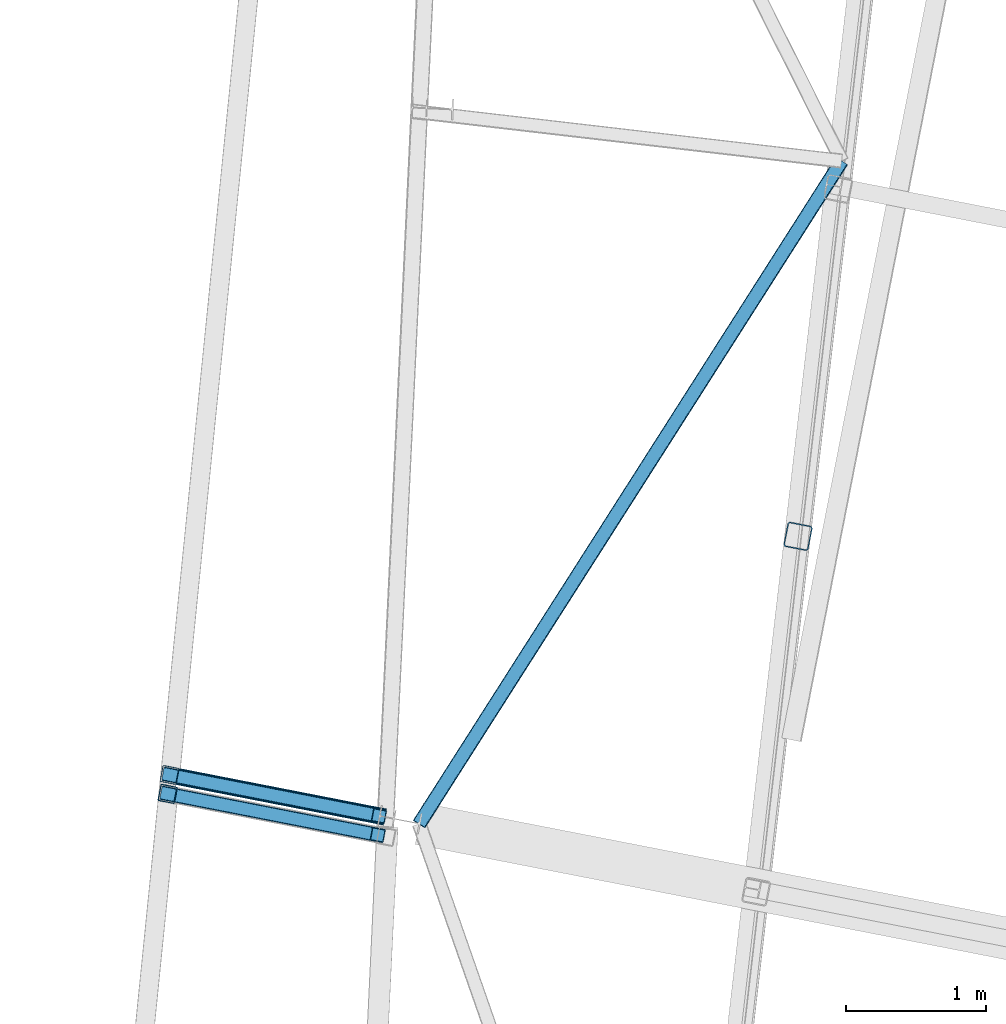
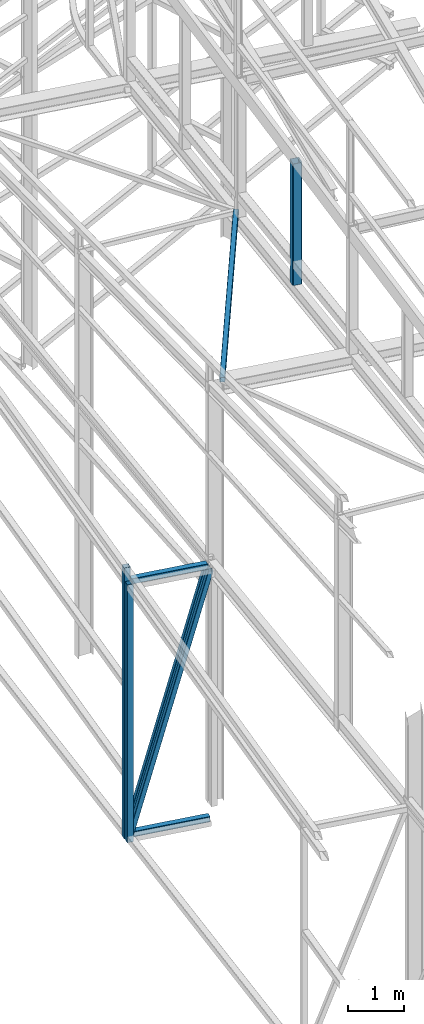
# One storey, part 72 of 215: 6 beams, 2 members, 8 elements without a shape of their own.
"""IFC2X3 building model written with IfcOpenShell, lengths in millimetres."""

from ifc_helpers import new_model, si_unit, frame, origin_with_axes, origin_2d_with_axis, place, context, subcontext, project, spatial, hollow_rectangle, extrude, clip, halfspace, material, type_object, element, aggregate, save


model = new_model("IFC2X3")

# Units and contexts
model_context = context("Model", 3, precision=1e-05, world=origin_with_axes())
body_context = subcontext(model_context, "Body", "Model", "MODEL_VIEW")
ifc_project = project(units=[si_unit("LENGTHUNIT", "METRE", prefix="MILLI"), si_unit("AREAUNIT", "SQUARE_METRE"), si_unit("VOLUMEUNIT", "CUBIC_METRE"), si_unit("MASSUNIT", "GRAM", prefix="KILO"), si_unit("TIMEUNIT", "SECOND"), si_unit("PLANEANGLEUNIT", "RADIAN"), si_unit("SOLIDANGLEUNIT", "STERADIAN"), si_unit("THERMODYNAMICTEMPERATUREUNIT", "DEGREE_CELSIUS"), si_unit("LUMINOUSINTENSITYUNIT", "LUMEN")], contexts=[model_context])

# Site, building, storey
site_placement = place(None, origin_with_axes())
site = spatial("IfcSite", under=ifc_project, at=site_placement, CompositionType="ELEMENT")
building_placement = place(site_placement, origin_with_axes())
building = spatial("IfcBuilding", under=site, at=building_placement, Name="Undefined", CompositionType="ELEMENT")
storey_placement = place(building_placement, origin_with_axes())
storey = spatial("IfcBuildingStorey", under=building, at=storey_placement, Name="Undefined", CompositionType="ELEMENT", Elevation=0.0)

# Assembly, beam
assembly_1_placement = place(storey_placement, origin_with_axes())
assembly_1 = element("IfcElementAssembly", 1, at=assembly_1_placement, inside=storey, Name="Steel Assembly", AssemblyPlace="NOTDEFINED", PredefinedType="RIGID_FRAME")
ifc_material_1 = material(Name="STEEL/S235JR")
beam_type_1 = type_object("IfcBeamType", PredefinedType="NOTDEFINED")
beam_1_placement = place(assembly_1_placement, frame((37010.032781368, 44444.6890852761, 5190.81618443027), z_axis=(-0.981475092367809, 0.1915897780718, 0.0), x_axis=(0.0, 0.0, -1.0)))
beam_1 = element("IfcBeam", 2, at=beam_1_placement, type_object=beam_type_1, material=ifc_material_1, Name="LISSE", context=body_context, shape_type="SweptSolid", body=[
    extrude(hollow_rectangle(XDim=120.0, YDim=120.0, WallThickness=4.0, InnerFilletRadius=4.0, OuterFilletRadius=8.0, at=origin_2d_with_axis()), frame((5615.19062771727, 0.0, 0.0), z_axis=(-1.0, 0.0, 0.0), x_axis=(-6.93889390390723e-18, -1.0, -3.46944695195361e-18)), (0.0, 0.0, 1.0), 5615.2),
])
aggregate(assembly_1, [beam_1])

assembly_2_placement = place(storey_placement, origin_with_axes())
assembly_2 = element("IfcElementAssembly", 3, at=assembly_2_placement, inside=storey, Name="Steel Assembly", AssemblyPlace="NOTDEFINED", PredefinedType="RIGID_FRAME")
ifc_material_2 = material(Name="STEEL/S275JR")
beam_type_2 = type_object("IfcBeamType", PredefinedType="NOTDEFINED")
beam_2_placement = place(assembly_2_placement, frame((37023.6070583032, 44579.5351782983, 5473.02196714264), z_axis=(-0.981422412140383, 0.191859451027444, 0.0), x_axis=(0.0, 0.0, -1.0)))
beam_2 = element("IfcBeam", 4, at=beam_2_placement, type_object=beam_type_2, material=ifc_material_2, Name="MONTANT", context=body_context, shape_type="SweptSolid", body=[
    extrude(hollow_rectangle(XDim=120.0, YDim=120.0, WallThickness=5.0, InnerFilletRadius=5.0, OuterFilletRadius=10.0, at=origin_2d_with_axis()), frame((5900.60047417997, 0.0, 0.0), z_axis=(-1.0, 0.0, 0.0), x_axis=(-6.93889390390723e-18, -1.0, -3.46944695195361e-18)), (0.0, 0.0, 1.0), 5900.6),
])
aggregate(assembly_2, [beam_2])

assembly_3_placement = place(storey_placement, origin_with_axes())
assembly_3 = element("IfcElementAssembly", 5, at=assembly_3_placement, inside=storey, Name="Steel Assembly", AssemblyPlace="NOTDEFINED", PredefinedType="RIGID_FRAME")
beam_3_placement = place(assembly_3_placement, frame((37082.4982339329, 44568.0501831909, -367.578507511368), z_axis=(0.0, 0.0, 1.0), x_axis=(0.981473467246252, -0.191598103048073, 0.0)))
beam_3 = element("IfcBeam", 6, at=beam_3_placement, type_object=beam_type_2, material=ifc_material_2, Name="POUTRE", context=body_context, shape_type="SweptSolid", body=[
    extrude(hollow_rectangle(XDim=120.0, YDim=120.0, WallThickness=5.0, InnerFilletRadius=5.0, OuterFilletRadius=10.0, at=origin_2d_with_axis()), frame((1505.13180523753, 0.0, -5.6843418860808e-14), z_axis=(-1.0, 0.0, 0.0), x_axis=(-6.93889390390723e-18, -1.0, -3.46944695195361e-18)), (0.0, 0.0, 1.0), 1505.1),
])
aggregate(assembly_3, [beam_3])

assembly_4_placement = place(storey_placement, origin_with_axes())
assembly_4 = element("IfcElementAssembly", 7, at=assembly_4_placement, inside=storey, Name="Steel Assembly", AssemblyPlace="NOTDEFINED", PredefinedType="RIGID_FRAME")
beam_4_placement = place(assembly_4_placement, frame((37082.434443744, 44568.0348814907, 5145.44143051328), z_axis=(0.0, 0.0, 1.0), x_axis=(0.981476961226487, -0.19158020404421, 0.0)))
beam_4 = element("IfcBeam", 8, at=beam_4_placement, type_object=beam_type_2, material=ifc_material_2, Name="POUTRE", context=body_context, shape_type="SweptSolid", body=[
    extrude(hollow_rectangle(XDim=120.0, YDim=120.0, WallThickness=5.0, InnerFilletRadius=5.0, OuterFilletRadius=10.0, at=origin_2d_with_axis()), frame((1461.26846974386, 0.0, 0.0), z_axis=(-1.0, 0.0, 0.0), x_axis=(-6.93889390390723e-18, -1.0, -3.46944695195361e-18)), (0.0, 0.0, 1.0), 1461.3),
])
aggregate(assembly_4, [beam_4])

assembly_5_placement = place(storey_placement, origin_with_axes())
assembly_5 = element("IfcElementAssembly", 9, at=assembly_5_placement, inside=storey, Name="Steel Assembly", AssemblyPlace="NOTDEFINED", PredefinedType="RIGID_FRAME")
beam_type_3 = type_object("IfcBeamType", PredefinedType="NOTDEFINED")
beam_5_placement = place(assembly_5_placement, frame((41812.5715276754, 48952.9868019976, 8864.68091067583), z_axis=(0.843649683396808, -0.536453236252318, 0.0217517130102304), x_axis=(-0.536863214924984, -0.84247447788228, 0.0448847699937281)))
beam_5 = element("IfcBeam", 10, at=beam_5_placement, type_object=beam_type_3, material=ifc_material_2, context=body_context, shape_type="SweptSolid", body=[
    extrude(hollow_rectangle(XDim=100.0, YDim=100.0, WallThickness=5.0, InnerFilletRadius=5.0, OuterFilletRadius=10.0, at=origin_2d_with_axis()), frame((5606.96022167192, 3.89061021016096e-14, -2.01217496806762e-13), z_axis=(-1.0, 0.0, 0.0), x_axis=(-6.93889390390723e-18, -1.0, -3.46944695195361e-18)), (0.0, 0.0, 1.0), 5607.0),
])
aggregate(assembly_5, [beam_5])

# Assembly, member
assembly_6_placement = place(storey_placement, origin_with_axes())
assembly_6 = element("IfcElementAssembly", 11, at=assembly_6_placement, inside=storey, Name="Steel Assembly", AssemblyPlace="NOTDEFINED", PredefinedType="RIGID_FRAME")
member_type = type_object("IfcMemberType", PredefinedType="NOTDEFINED")
member_1_placement = place(assembly_6_placement, frame((37010.0327804725, 44444.6890853494, -345.378507440011), z_axis=(-0.945443190632201, 0.184552778928203, 0.268472428895559), x_axis=(0.263499001950999, -0.0514365729904346, 0.963287368820866)))
member_1 = element("IfcMember", 12, at=member_1_placement, type_object=member_type, material=ifc_material_2, Name="POUTRE", context=body_context, shape_type="SweptSolid", body=[
    extrude(hollow_rectangle(XDim=100.0, YDim=100.0, WallThickness=5.0, InnerFilletRadius=5.0, OuterFilletRadius=10.0, at=origin_2d_with_axis()), frame((5684.90241798571, 7.28434454547628e-15, 3.15575477859748e-13), z_axis=(-1.0, 0.0, 0.0), x_axis=(-6.93889390390723e-18, -1.0, -3.46944695195361e-18)), (0.0, 0.0, 1.0), 5684.9),
])
aggregate(assembly_6, [member_1])

assembly_7_placement = place(storey_placement, origin_with_axes())
assembly_7 = element("IfcElementAssembly", 13, at=assembly_7_placement, inside=storey, Name="Steel Assembly", AssemblyPlace="NOTDEFINED", PredefinedType="RIGID_FRAME")
member_2_placement = place(assembly_7_placement, frame((37023.6026303952, 44579.5535906216, -337.578507418732), z_axis=(-0.945749576500691, 0.184622434902526, 0.267343028858855), x_axis=(0.26238986907138, -0.0512235470139345, 0.963601424262135)))
member_2 = element("IfcMember", 14, at=member_2_placement, type_object=member_type, material=ifc_material_2, Name="POUTRE", context=body_context, shape_type="SweptSolid", body=[
    extrude(hollow_rectangle(XDim=100.0, YDim=100.0, WallThickness=5.0, InnerFilletRadius=5.0, OuterFilletRadius=10.0, at=origin_2d_with_axis()), frame((5690.13266111088, 2.90328476129097e-14, -3.95384462176856e-12), z_axis=(-1.0, 0.0, 0.0), x_axis=(-6.93889390390723e-18, -1.0, -3.46944695195361e-18)), (0.0, 0.0, 1.0), 5690.1),
])
aggregate(assembly_7, [member_2])

# Assembly, beam
assembly_8_placement = place(storey_placement, origin_with_axes())
assembly_8 = element("IfcElementAssembly", 15, at=assembly_8_placement, inside=storey, Name="Steel Assembly", AssemblyPlace="NOTDEFINED", PredefinedType="RIGID_FRAME")
beam_type_4 = type_object("IfcBeamType", PredefinedType="NOTDEFINED")
beam_6_placement = place(assembly_8_placement, frame((41502.123498963, 46279.686765684, 11700.1155677473), z_axis=(-0.981422412140383, 0.191859451027444, 0.0), x_axis=(0.0, 0.0, -1.0)))
beam_6 = element("IfcBeam", 16, at=beam_6_placement, type_object=beam_type_4, material=ifc_material_2, Name="MONTANT", context=body_context, shape_type="Clipping", body=[
    clip(extrude(hollow_rectangle(XDim=180.0, YDim=180.0, WallThickness=8.0, InnerFilletRadius=12.0, OuterFilletRadius=20.0, at=origin_2d_with_axis()), frame((2656.17638011198, 0.0, 0.0), z_axis=(-1.0, 0.0, 0.0), x_axis=(-6.93889390390723e-18, -1.0, -3.46944695195361e-18)), (0.0, 0.0, 1.0), 2656.2), halfspace(frame((2662.43191165634, -215.402222344761, 106.975085024351), z_axis=(-0.998757541180045, -0.0496840699304531, 0.00385579189483438), x_axis=(0.0, -0.0773735506072624, -0.997002173350904)), True)),
])
aggregate(assembly_8, [beam_6])

save(model, "model.ifc")
